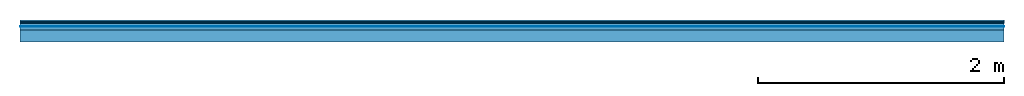
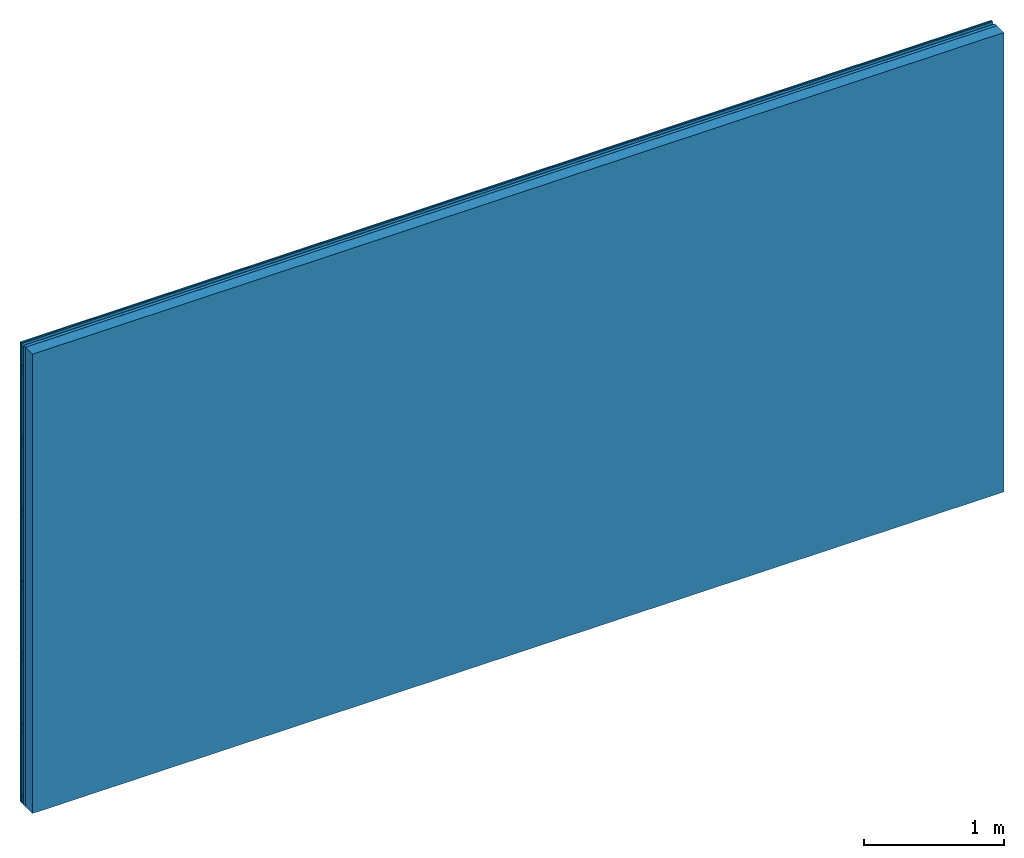
# One storey: 4 plates, 2 members, 1 element without a shape of its own.
"""IFC4 building model written with IfcOpenShell, lengths in metres."""

from ifc_helpers import new_model, si_unit, derived_unit, direction, frame, frame_2d, origin, origin_with_axes, place, context, project, spatial, rectangle, extrude, material, layer, layer_set, type_object, element, aggregate, save


model = new_model("IFC4")

# Units and contexts
plan_context = context("Plan", 3, precision=1e-05, world=origin(), true_north=direction((0.0, 1.0)))
model_context = context("Model", 3, precision=1e-05, world=origin(), true_north=direction((0.0, 1.0)))
ifc_project = project(units=[si_unit("LENGTHUNIT", "METRE"), derived_unit("SOUNDPRESSUREUNIT", [(si_unit("PRESSUREUNIT", "PASCAL", prefix="MICRO"), 0)]), si_unit("ENERGYUNIT", "JOULE", prefix="MEGA"), si_unit("MASSUNIT", "GRAM", prefix="KILO"), derived_unit("THERMALTRANSMITTANCEUNIT", [(si_unit("POWERUNIT", "WATT"), 1), (si_unit("AREAUNIT", "SQUARE_METRE"), -1), (si_unit("THERMODYNAMICTEMPERATUREUNIT", "KELVIN"), -1)]), derived_unit("AREADENSITYUNIT", [(si_unit("MASSUNIT", "GRAM", prefix="KILO"), 1), (si_unit("AREAUNIT", "SQUARE_METRE"), -1)]), derived_unit("USERDEFINED", [(si_unit("ENERGYUNIT", "JOULE", prefix="MEGA"), 1), (si_unit("AREAUNIT", "SQUARE_METRE"), -1)])], contexts=[plan_context, model_context])

# Site, building, storey
site = spatial("IfcSite", under=ifc_project)
building_placement = place(None, origin())
building = spatial("IfcBuilding", under=site, at=building_placement)
storey_placement = place(building_placement, origin())
storey = spatial("IfcBuildingStorey", under=building, at=storey_placement)

# Wall, members, plates
ifc_material_1 = material(Name="joints", Category="04.017")
ifc_layer_1 = layer(ifc_material_1, 0.0, Name="Surface")
ifc_material_2 = material(Name="Rigidur H", Category="03.007")
ifc_layer_2 = layer(ifc_material_2, 0.0125, Name="Cover 2nd layer")
ifc_layer_3 = layer(ifc_material_2, 0.0125, Name="Cover 1st layer")
ifc_layer_4 = layer(None, 0.027, Name="Battens / profiles")
ifc_material_3 = material(Name="Air")
ifc_layer_5 = layer(ifc_material_3, 0.001, Name="Coupling")
ifc_material_4 = material(Category="10.008")
ifc_layer_6 = layer(ifc_material_4, 0.027, Name="Cavity")
ifc_material_5 = material(Name="no composite action")
ifc_layer_7 = layer(ifc_material_5, 0.0, Name="Bond")
ifc_layer_8 = layer(None, 0.1, Name="Support")
ifc_layer_set = layer_set([ifc_layer_1, ifc_layer_2, ifc_layer_3, ifc_layer_4, ifc_layer_5, ifc_layer_6, ifc_layer_7, ifc_layer_8])
wall_type = type_object("IfcWallType", Name="C0476", PredefinedType="NOTDEFINED", material=ifc_layer_set)
wall_placement = place(None, frame((0.0, 0.0, 0.0), z_axis=(0.0, -1.0, 0.0), x_axis=(1.0, 0.0, 0.0)))
wall = element("IfcWall", 1, at=wall_placement, inside=storey, type_object=wall_type, material=ifc_layer_set, Name="Wall #1")
ifc_material_6 = material()
member_1_placement = place(wall_placement, origin())
member_1 = element("IfcMember", 2, at=member_1_placement, material=ifc_material_6, Name="Battens / profiles", context=plan_context, shape_type="SweptSolid", body=[
    extrude(rectangle(XDim=0.06, YDim=0.027, at=frame_2d((0.03, 0.0135), x_axis=(1.0, 0.0))), frame((0.0, 0.0, 0.025), z_axis=(1.0, 0.0, 0.0), x_axis=(0.0, 1.0, 0.0)), (0.0, 0.0, 1.0), 8.0),
    extrude(rectangle(XDim=0.06, YDim=0.027, at=frame_2d((0.03, 0.0135), x_axis=(1.0, 0.0))), frame((0.0, 0.625, 0.025), z_axis=(1.0, 0.0, 0.0), x_axis=(0.0, 1.0, 0.0)), (0.0, 0.0, 1.0), 8.0),
    extrude(rectangle(XDim=0.06, YDim=0.027, at=frame_2d((0.03, 0.0135), x_axis=(1.0, 0.0))), frame((0.0, 1.25, 0.025), z_axis=(1.0, 0.0, 0.0), x_axis=(0.0, 1.0, 0.0)), (0.0, 0.0, 1.0), 8.0),
    extrude(rectangle(XDim=0.06, YDim=0.027, at=frame_2d((0.03, 0.0135), x_axis=(1.0, 0.0))), frame((0.0, 1.875, 0.025), z_axis=(1.0, 0.0, 0.0), x_axis=(0.0, 1.0, 0.0)), (0.0, 0.0, 1.0), 8.0),
    extrude(rectangle(XDim=0.06, YDim=0.027, at=frame_2d((0.03, 0.0135), x_axis=(1.0, 0.0))), frame((0.0, 2.5, 0.025), z_axis=(1.0, 0.0, 0.0), x_axis=(0.0, 1.0, 0.0)), (0.0, 0.0, 1.0), 8.0),
    extrude(rectangle(XDim=0.06, YDim=0.027, at=frame_2d((0.03, 0.0135), x_axis=(1.0, 0.0))), frame((0.0, 3.125, 0.025), z_axis=(1.0, 0.0, 0.0), x_axis=(0.0, 1.0, 0.0)), (0.0, 0.0, 1.0), 8.0),
    extrude(rectangle(XDim=0.06, YDim=0.027, at=frame_2d((0.03, 0.0135), x_axis=(1.0, 0.0))), frame((0.0, 3.75, 0.025), z_axis=(1.0, 0.0, 0.0), x_axis=(0.0, 1.0, 0.0)), (0.0, 0.0, 1.0), 8.0),
])
ifc_material_7 = material(Name="OSB")
member_2_placement = place(wall_placement, origin())
member_2 = element("IfcMember", 3, at=member_2_placement, material=ifc_material_7, Name="Support", context=plan_context, shape_type="SweptSolid", body=[
    extrude(rectangle(XDim=1.0, YDim=0.1, at=frame_2d((0.5, 0.05), x_axis=(1.0, 0.0))), frame((0.0, 4.0, 0.08), z_axis=(0.0, -1.0, 0.0), x_axis=(1.0, 0.0, 0.0)), (0.0, 0.0, 1.0), 4.0),
    extrude(rectangle(XDim=1.0, YDim=0.1, at=frame_2d((0.5, 0.05), x_axis=(1.0, 0.0))), frame((1.0, 4.0, 0.08), z_axis=(0.0, -1.0, 0.0), x_axis=(1.0, 0.0, 0.0)), (0.0, 0.0, 1.0), 4.0),
    extrude(rectangle(XDim=1.0, YDim=0.1, at=frame_2d((0.5, 0.05), x_axis=(1.0, 0.0))), frame((2.0, 4.0, 0.08), z_axis=(0.0, -1.0, 0.0), x_axis=(1.0, 0.0, 0.0)), (0.0, 0.0, 1.0), 4.0),
    extrude(rectangle(XDim=1.0, YDim=0.1, at=frame_2d((0.5, 0.05), x_axis=(1.0, 0.0))), frame((3.0, 4.0, 0.08), z_axis=(0.0, -1.0, 0.0), x_axis=(1.0, 0.0, 0.0)), (0.0, 0.0, 1.0), 4.0),
    extrude(rectangle(XDim=1.0, YDim=0.1, at=frame_2d((0.5, 0.05), x_axis=(1.0, 0.0))), frame((4.0, 4.0, 0.08), z_axis=(0.0, -1.0, 0.0), x_axis=(1.0, 0.0, 0.0)), (0.0, 0.0, 1.0), 4.0),
    extrude(rectangle(XDim=1.0, YDim=0.1, at=frame_2d((0.5, 0.05), x_axis=(1.0, 0.0))), frame((5.0, 4.0, 0.08), z_axis=(0.0, -1.0, 0.0), x_axis=(1.0, 0.0, 0.0)), (0.0, 0.0, 1.0), 4.0),
    extrude(rectangle(XDim=1.0, YDim=0.1, at=frame_2d((0.5, 0.05), x_axis=(1.0, 0.0))), frame((6.0, 4.0, 0.08), z_axis=(0.0, -1.0, 0.0), x_axis=(1.0, 0.0, 0.0)), (0.0, 0.0, 1.0), 4.0),
    extrude(rectangle(XDim=1.0, YDim=0.1, at=frame_2d((0.5, 0.05), x_axis=(1.0, 0.0))), frame((7.0, 4.0, 0.08), z_axis=(0.0, -1.0, 0.0), x_axis=(1.0, 0.0, 0.0)), (0.0, 0.0, 1.0), 4.0),
])
plate_1_placement = place(wall_placement, origin())
plate_1 = element("IfcPlate", 4, at=plate_1_placement, material=ifc_material_2, Name="Cover 2nd layer", context=plan_context, shape_type="SweptSolid", body=[
    extrude(rectangle(XDim=8.0, YDim=4.0, at=frame_2d((4.0, 2.0), x_axis=(1.0, 0.0))), origin_with_axes(), (0.0, 0.0, 1.0), 0.0125),
])
plate_2_placement = place(wall_placement, origin())
plate_2 = element("IfcPlate", 5, at=plate_2_placement, material=ifc_material_2, Name="Cover 1st layer", context=plan_context, shape_type="SweptSolid", body=[
    extrude(rectangle(XDim=8.0, YDim=4.0, at=frame_2d((4.0, 2.0), x_axis=(1.0, 0.0))), frame((0.0, 0.0, 0.0125), z_axis=(0.0, 0.0, 1.0), x_axis=(1.0, 0.0, 0.0)), (0.0, 0.0, 1.0), 0.0125),
])
plate_3_placement = place(wall_placement, origin())
plate_3 = element("IfcPlate", 6, at=plate_3_placement, material=ifc_material_3, Name="Coupling", context=plan_context, shape_type="SweptSolid", body=[
    extrude(rectangle(XDim=8.0, YDim=4.0, at=frame_2d((4.0, 2.0), x_axis=(1.0, 0.0))), frame((0.0, 0.0, 0.052), z_axis=(0.0, 0.0, 1.0), x_axis=(1.0, 0.0, 0.0)), (0.0, 0.0, 1.0), 0.001),
])
plate_4_placement = place(wall_placement, origin())
plate_4 = element("IfcPlate", 7, at=plate_4_placement, material=ifc_material_4, Name="Cavity", context=plan_context, shape_type="SweptSolid", body=[
    extrude(rectangle(XDim=8.0, YDim=4.0, at=frame_2d((4.0, 2.0), x_axis=(1.0, 0.0))), frame((0.0, 0.0, 0.053), z_axis=(0.0, 0.0, 1.0), x_axis=(1.0, 0.0, 0.0)), (0.0, 0.0, 1.0), 0.027),
])
aggregate(wall, [plate_1, plate_2, member_1, plate_3, plate_4, member_2])

save(model, "model.ifc")
